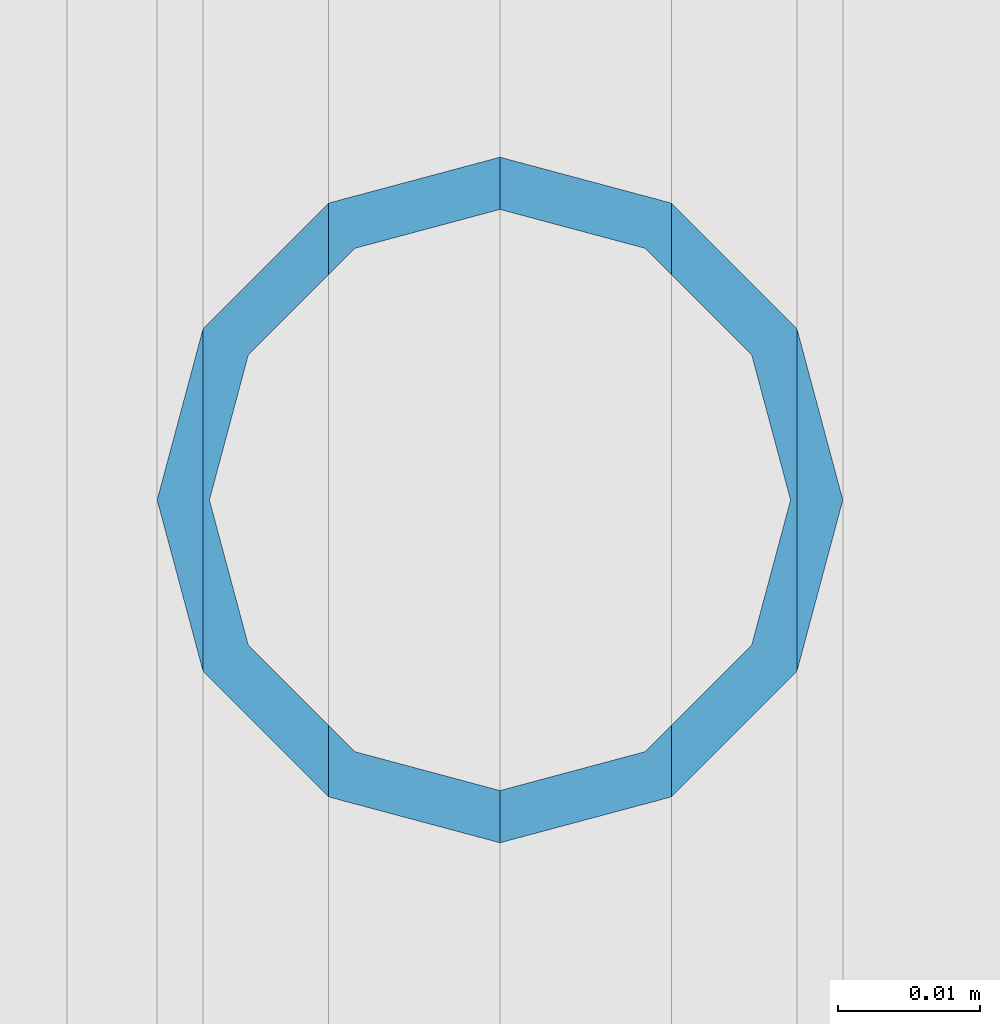
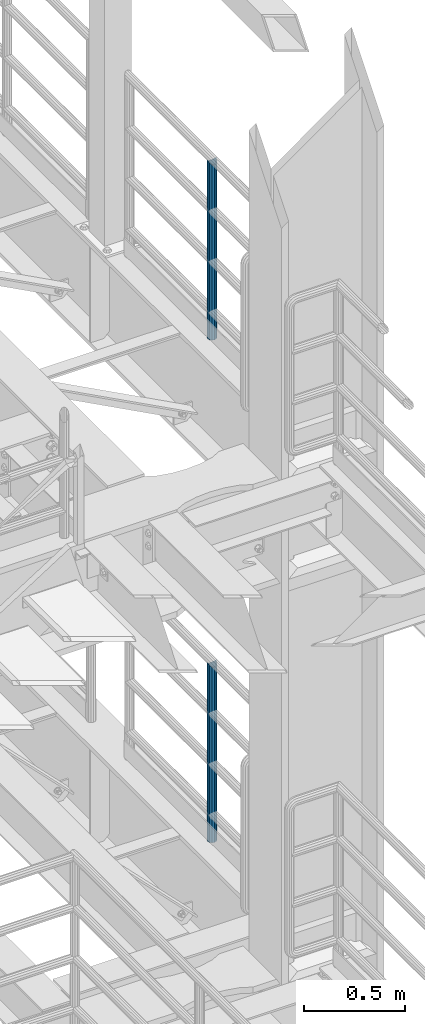
# One storey, part 670 of 1876: 2 columns, 2 elements without a shape of their own.
"""IFC2X3 building model written with IfcOpenShell, lengths in millimetres."""

from ifc_helpers import new_model, si_unit, frame, origin_with_axes, place, context, subcontext, project, spatial, faceted_brep, material, type_object, element, aggregate, save


model = new_model("IFC2X3")

# Units and contexts
model_context = context("Model", 3, precision=1e-05, world=origin_with_axes())
body_context = subcontext(model_context, "Body", "Model", "MODEL_VIEW")
ifc_project = project(units=[si_unit("LENGTHUNIT", "METRE", prefix="MILLI"), si_unit("AREAUNIT", "SQUARE_METRE"), si_unit("VOLUMEUNIT", "CUBIC_METRE"), si_unit("MASSUNIT", "GRAM", prefix="KILO"), si_unit("TIMEUNIT", "SECOND"), si_unit("PLANEANGLEUNIT", "RADIAN"), si_unit("SOLIDANGLEUNIT", "STERADIAN"), si_unit("THERMODYNAMICTEMPERATUREUNIT", "DEGREE_CELSIUS"), si_unit("LUMINOUSINTENSITYUNIT", "LUMEN")], contexts=[model_context])

# Site, building, storey
site_placement = place(None, origin_with_axes())
site = spatial("IfcSite", under=ifc_project, at=site_placement, CompositionType="ELEMENT")
building_placement = place(site_placement, origin_with_axes())
building = spatial("IfcBuilding", under=site, at=building_placement, Name="Undefined", CompositionType="ELEMENT")
storey_placement = place(building_placement, origin_with_axes())
storey = spatial("IfcBuildingStorey", under=building, at=storey_placement, Name="Undefined", CompositionType="ELEMENT", Elevation=0.0)

# Assembly, column
assembly_1_placement = place(storey_placement, origin_with_axes())
assembly_1 = element("IfcElementAssembly", 1, at=assembly_1_placement, inside=storey, Name="RAIL", AssemblyPlace="NOTDEFINED", PredefinedType="RIGID_FRAME")
ifc_material = material()
column_type = type_object("IfcColumnType", Name="PIPE1-1/2SCH40", PredefinedType="NOTDEFINED")
column_1_placement = place(assembly_1_placement, frame((7620.0, -3542.7031, 8153.4), z_axis=(0.0, 1.0, 0.0), x_axis=(0.0, 0.0, 1.0)))
column_1 = element("IfcColumn", 2, at=column_1_placement, type_object=column_type, material=ifc_material, Name="POST", ObjectType="PIPE1-1/2SCH40", context=body_context, shape_type="Brep", body=[
    faceted_brep([(1055.42780700668, -12.0650000000001, 20.8971929933186), (1055.42780700668, -12.0650000000001, 15.8661214311805), (1054.93437856882, -10.2235000000001, 17.7076214311801), (1052.195, 0.0, 20.4470000000001), (1052.195, 0.0, 24.1300000000001), (1054.93437856882, 10.2235000000001, 17.7076214311801), (1055.42780700668, 12.0650000000001, 15.8661214311805), (1055.42780700668, 12.0650000000001, 20.8971929933186), (1076.325, 24.1300000000001, 0.0), (1064.26, 20.8971929933184, 12.0649999999996), (1064.25999999999, 20.8971929933186, -12.0649999999996), (1061.07042843786, 17.7076214311803, 10.2235000000001), (1063.80980700668, 20.4469999999999, 0.0), (1061.07042843786, 17.7076214311803, -10.2235000000001), (1055.42780700668, 12.0650000000001, -15.8661214311805), (1055.42780700667, 12.0649999999996, -20.8971929933186), (1054.93437856882, 10.2235000000001, -17.7076214311801), (1052.195, 0.0, -20.4470000000001), (1052.19499999999, 0.0, -24.1300000000001), (1055.42780700668, -12.0650000000001, -15.8661214311805), (1055.42780700667, -12.0649999999996, -20.8971929933186), (1054.93437856882, -10.2235000000001, -17.7076214311801), (1076.325, -24.1300000000001, 0.0), (1064.25999999999, -20.8971929933186, -12.0649999999996), (1064.26, -20.8971929933184, 12.0649999999996), (1061.07042843786, -17.7076214311803, -10.2235000000001), (1063.80980700668, -20.4469999999999, 0.0), (1061.07042843786, -17.7076214311803, 10.2235000000001), (0.0, -20.8971929933184, -12.0649999999996), (0.0, -12.0650000000001, -20.8971929933186), (-1.45519152283669e-11, 0.0, -24.130000000001), (0.0, 12.0650000000001, -20.8971929933186), (0.0, 20.8971929933184, -12.0649999999996), (0.0, 24.1299999999992, 0.0), (0.0, 20.8971929933184, 12.0649999999996), (0.0, 12.0650000000001, 20.8971929933186), (-1.45519152283669e-11, 0.0, 24.130000000001), (0.0, -12.0650000000001, 20.8971929933186), (0.0, -20.8971929933184, 12.0649999999996), (0.0, -24.1299999999992, 0.0), (0.0, -17.7076214311803, -10.2235000000001), (0.0, -10.2235000000001, -17.7076214311801), (-1.45519152283669e-11, 0.0, -20.4470000000001), (0.0, 10.2235000000001, -17.7076214311801), (0.0, 17.7076214311803, -10.2235000000001), (0.0, 20.4469999999999, 0.0), (0.0, 17.7076214311803, 10.2235000000001), (0.0, 10.2235000000001, 17.7076214311801), (-1.45519152283669e-11, 0.0, 20.4470000000001), (0.0, -10.2235000000001, 17.7076214311801), (0.0, -17.7076214311803, 10.2235000000001), (0.0, -20.4469999999999, 0.0)], [[[0, 1, 2, 3, 4]], [[4, 3, 5, 6, 7]], [[8, 9, 10]], [[7, 6, 11, 12, 13, 14, 15, 10, 9]], [[16, 17, 18, 15, 14]], [[19, 20, 18, 17, 21]], [[22, 23, 24]], [[24, 23, 20, 19, 25, 26, 27, 1, 0]], [[28, 29, 20, 23]], [[29, 30, 18, 20]], [[30, 31, 15, 18]], [[31, 32, 10, 15]], [[32, 33, 8, 10]], [[33, 34, 9, 8]], [[34, 35, 7, 9]], [[35, 36, 4, 7]], [[36, 37, 0, 4]], [[37, 38, 24, 0]], [[38, 39, 22, 24]], [[39, 28, 23, 22]], [[38, 37, 36, 35, 34, 33, 32, 31, 30, 29, 28, 39], [40, 41, 42, 43, 44, 45, 46, 47, 48, 49, 50, 51]], [[40, 51, 26, 25]], [[21, 41, 40, 25, 19]], [[42, 41, 21, 17]], [[43, 42, 17, 16]], [[44, 43, 16, 14, 13]], [[45, 44, 13, 12]], [[46, 45, 12, 11]], [[5, 47, 46, 11, 6]], [[48, 47, 5, 3]], [[49, 48, 3, 2]], [[50, 49, 2, 1, 27]], [[51, 50, 27, 26]]]),
])
aggregate(assembly_1, [column_1])

assembly_2_placement = place(storey_placement, origin_with_axes())
assembly_2 = element("IfcElementAssembly", 3, at=assembly_2_placement, inside=storey, Name="RAIL", AssemblyPlace="NOTDEFINED", PredefinedType="RIGID_FRAME")
column_2_placement = place(assembly_2_placement, frame((7620.0, -3542.70310000001, 5130.8), z_axis=(0.0, 1.0, 0.0), x_axis=(0.0, 0.0, 1.0)))
column_2 = element("IfcColumn", 4, at=column_2_placement, type_object=column_type, material=ifc_material, Name="POST", ObjectType="PIPE1-1/2SCH40", context=body_context, shape_type="Brep", body=[
    faceted_brep([(1055.42780700668, -12.0650000000001, 20.8971929933186), (1055.42780700668, -12.0650000000001, 15.8661214311805), (1054.93437856882, -10.2235000000001, 17.7076214311801), (1052.195, 0.0, 20.4470000000001), (1052.195, 0.0, 24.1300000000001), (1054.93437856882, 10.2235000000001, 17.7076214311801), (1055.42780700668, 12.0650000000001, 15.8661214311805), (1055.42780700668, 12.0650000000001, 20.8971929933186), (1076.325, 24.1300000000001, 0.0), (1064.26, 20.8971929933184, 12.0649999999996), (1064.25999999999, 20.8971929933186, -12.0649999999996), (1061.07042843786, 17.7076214311803, 10.2235000000001), (1063.80980700668, 20.4469999999999, 0.0), (1061.07042843786, 17.7076214311803, -10.2235000000001), (1055.42780700668, 12.0650000000001, -15.8661214311805), (1055.42780700667, 12.0649999999996, -20.8971929933186), (1054.93437856882, 10.2235000000001, -17.7076214311801), (1052.195, 0.0, -20.4470000000001), (1052.19499999999, 0.0, -24.1300000000001), (1055.42780700668, -12.0650000000001, -15.8661214311805), (1055.42780700667, -12.0649999999996, -20.8971929933186), (1054.93437856882, -10.2235000000001, -17.7076214311801), (1076.325, -24.1300000000001, 0.0), (1064.25999999999, -20.8971929933186, -12.0649999999996), (1064.26, -20.8971929933184, 12.0649999999996), (1061.07042843786, -17.7076214311803, -10.2235000000001), (1063.80980700668, -20.4469999999999, 0.0), (1061.07042843786, -17.7076214311803, 10.2235000000001), (0.0, -20.8971929933184, -12.0649999999996), (0.0, -12.0650000000001, -20.8971929933186), (-1.45519152283669e-11, 0.0, -24.130000000001), (0.0, 12.0650000000001, -20.8971929933186), (0.0, 20.8971929933184, -12.0649999999996), (0.0, 24.1299999999992, 0.0), (0.0, 20.8971929933184, 12.0649999999996), (0.0, 12.0650000000001, 20.8971929933186), (-1.45519152283669e-11, 0.0, 24.130000000001), (0.0, -12.0650000000001, 20.8971929933186), (0.0, -20.8971929933184, 12.0649999999996), (0.0, -24.1299999999992, 0.0), (0.0, -17.7076214311803, -10.2235000000001), (0.0, -10.2235000000001, -17.7076214311801), (-1.45519152283669e-11, 0.0, -20.4470000000001), (0.0, 10.2235000000001, -17.7076214311801), (0.0, 17.7076214311803, -10.2235000000001), (0.0, 20.4469999999999, 0.0), (0.0, 17.7076214311803, 10.2235000000001), (0.0, 10.2235000000001, 17.7076214311801), (-1.45519152283669e-11, 0.0, 20.4470000000001), (0.0, -10.2235000000001, 17.7076214311801), (0.0, -17.7076214311803, 10.2235000000001), (0.0, -20.4469999999999, 0.0)], [[[0, 1, 2, 3, 4]], [[4, 3, 5, 6, 7]], [[8, 9, 10]], [[7, 6, 11, 12, 13, 14, 15, 10, 9]], [[16, 17, 18, 15, 14]], [[19, 20, 18, 17, 21]], [[22, 23, 24]], [[24, 23, 20, 19, 25, 26, 27, 1, 0]], [[28, 29, 20, 23]], [[29, 30, 18, 20]], [[30, 31, 15, 18]], [[31, 32, 10, 15]], [[32, 33, 8, 10]], [[33, 34, 9, 8]], [[34, 35, 7, 9]], [[35, 36, 4, 7]], [[36, 37, 0, 4]], [[37, 38, 24, 0]], [[38, 39, 22, 24]], [[39, 28, 23, 22]], [[38, 37, 36, 35, 34, 33, 32, 31, 30, 29, 28, 39], [40, 41, 42, 43, 44, 45, 46, 47, 48, 49, 50, 51]], [[40, 51, 26, 25]], [[21, 41, 40, 25, 19]], [[42, 41, 21, 17]], [[43, 42, 17, 16]], [[44, 43, 16, 14, 13]], [[45, 44, 13, 12]], [[46, 45, 12, 11]], [[5, 47, 46, 11, 6]], [[48, 47, 5, 3]], [[49, 48, 3, 2]], [[50, 49, 2, 1, 27]], [[51, 50, 27, 26]]]),
])
aggregate(assembly_2, [column_2])

save(model, "model.ifc")
